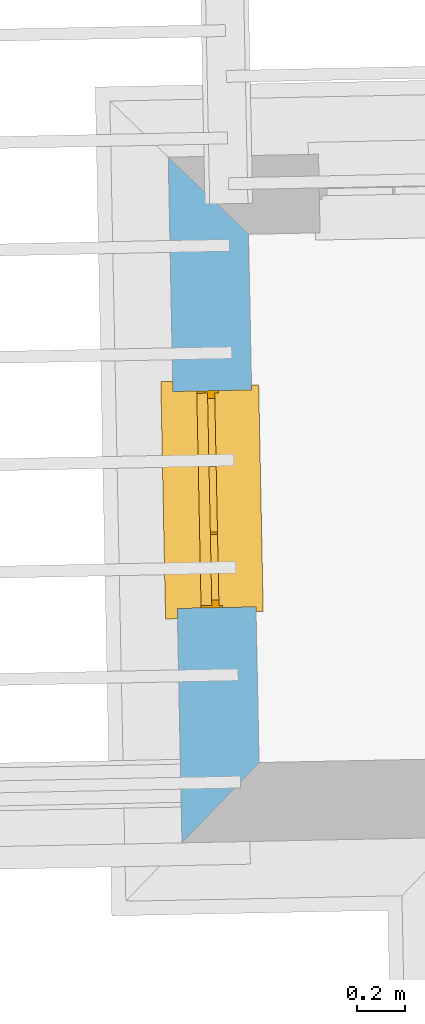
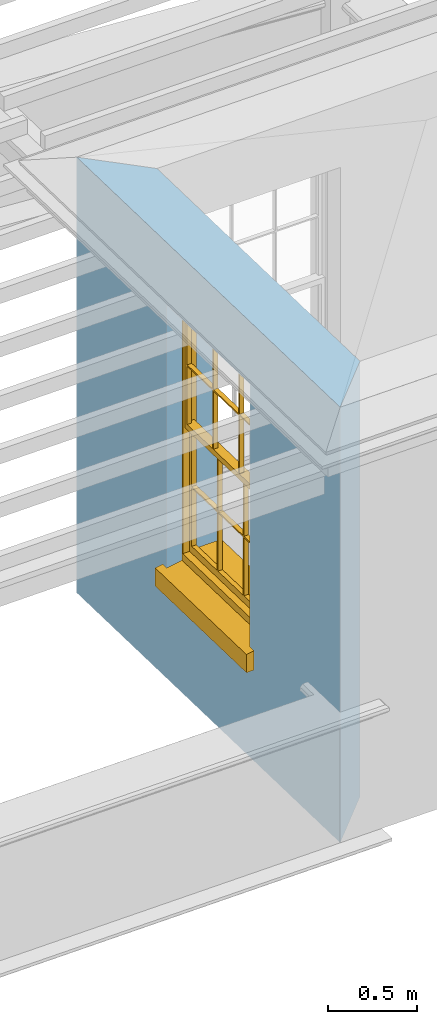
# One storey, part 6 of 11: 1 window, 1 opening, plus 1 element that does not belong to this part.
"""IFC2X3 building model written with IfcOpenShell, lengths in metres."""

from ifc_helpers import new_model, si_unit, frame, origin, place, context, subcontext, project, spatial, polyline, outline, extrude, faceted_brep, material, layer, layer_set, layer_usage, element, fill, save


model = new_model("IFC2X3")

# Units and contexts
model_context = context("Model", 3, world=origin())
body_context = subcontext(model_context, "Body", "Model", "MODEL_VIEW")
ifc_project = project(units=[si_unit("PLANEANGLEUNIT", "RADIAN"), si_unit("MASSUNIT", "GRAM", prefix="KILO"), si_unit("FORCEUNIT", "NEWTON", prefix="KILO"), si_unit("LENGTHUNIT", "METRE")], contexts=[model_context])

# Site, building, storey
site_placement = place(None, origin())
site = spatial("IfcSite", under=ifc_project, at=site_placement, CompositionType="ELEMENT")
building_placement = place(None, origin())
building = spatial("IfcBuilding", under=site, at=building_placement, Name="Building plot-11", CompositionType="ELEMENT")
storey_placement = place(None, frame((0.0, 0.0, 5.3)))
storey = spatial("IfcBuildingStorey", under=building, at=storey_placement, Name="Floor 1", CompositionType="ELEMENT", Elevation=5.3)

# Wall, opening, window
ifc_material = material(Name="Masonry")
ifc_layer = layer(ifc_material, 0.33, ventilated=False)
ifc_layer_set = layer_set([ifc_layer], Name="My Wall")
ifc_layer_usage = layer_usage(ifc_layer_set, "AXIS2", "NEGATIVE", 0.08)
wall_placement = place(storey_placement, origin())
wall = element("IfcWallStandardCase", 1, at=wall_placement, inside=storey, material=ifc_layer_usage, Name="exterior", context=body_context, shape_type="SweptSolid", body=[
    extrude(outline(polyline([(58.7998507375589, 22.5847820884662), (58.4633191417055, 22.9081185772706), (58.5207858909592, 20.0342901482081), (58.8441223797636, 20.3708217440617), (58.7998507375589, 22.5847820884662)])), origin(), (0.0, 0.0, 1.0), 3.0),
])
opening_placement = place(storey_placement, frame((0.0, 0.0, 0.75)))
opening = element("IfcOpeningElement", 2, at=opening_placement, cuts=wall, Name="Opening", ObjectType="Opening", context=body_context, shape_type="SweptSolid", body=[
    extrude(outline(polyline([(58.4829558895032, 21.926113421102), (58.5011491431615, 21.0162953043769), (58.8310831854904, 21.0228928579013), (58.8128899318321, 21.9327109746264), (58.4829558895032, 21.926113421102)])), origin(), (0.0, 0.0, 1.0), 1.82),
])
window_placement = place(storey_placement, frame((58.7329059215706, 21.9311115677114, 0.75), z_axis=(0.0, 0.0, 1.0), x_axis=(0.0181932536582607, -0.909818116725166, 0.0)))
window = element("IfcWindow", 3, at=window_placement, inside=storey, Name="circulation outside window", OverallHeight=1.82, OverallWidth=0.91, context=body_context, shape_type="Brep", held_by="IfcProductRepresentation", body=[
    faceted_brep([(0.033125, -0.105, 0.975209), (0.01, -0.105, 0.975209), (0.033125, -0.105, 1.376042), (0.876875, -0.105, 0.975209), (0.876875, -0.105, 1.376042), (0.9, -0.105, 0.975209), (0.876875, -0.105, 1.386042), (0.876875, -0.105, 1.786875), (0.9, -0.105, 1.81), (0.033125, -0.105, 1.786875), (0.033125, -0.105, 1.386042), (0.01, -0.105, 1.81), (0.876875, -0.135, 1.376042), (0.876875, -0.135, 0.975209), (0.9, -0.135, 0.937083), (0.033125, -0.135, 1.786875), (0.01, -0.135, 1.81), (0.033125, -0.135, 1.386042), (0.01, -0.135, 0.937083), (0.033125, -0.135, 0.975209), (0.033125, -0.135, 1.376042), (0.876875, -0.135, 1.786875), (0.876875, -0.135, 1.386042), (0.9, -0.135, 1.81), (0.033125, -0.105, 0.937083), (0.01, -0.105, 0.937083), (0.033125, -0.105, 0.53625), (0.876875, -0.105, 0.937083), (0.876875, -0.105, 0.53625), (0.9, -0.105, 0.937083), (0.876875, -0.105, 0.52625), (0.876875, -0.105, 0.125417), (0.9, -0.105, 0.077167), (0.033125, -0.105, 0.125417), (0.033125, -0.105, 0.52625), (0.01, -0.105, 0.077167), (-0.0425, -0.25, 0.01), (-0.0425, -0.3, 0.001667), (0.0, -0.25, 0.01), (0.9525, -0.25, 0.01), (0.91, -0.25, 0.01), (0.9525, -0.3, 0.001667), (-0.02, 0.08, 0.077167), (0.0, 0.08, 0.077167), (-0.02, 0.11, 0.077167), (0.0, -0.06, 0.077167), (0.01, -0.06, 0.077167), (0.91, -0.06, 0.077167), (0.91, 0.08, 0.077167), (0.9, -0.06, 0.077167), (0.93, 0.08, 0.077167), (0.93, 0.11, 0.077167), (0.01, -0.075, 0.975209), (0.9, -0.075, 0.975209), (0.876875, -0.075, 0.125417), (0.876875, -0.075, 0.52625), (0.9, -0.075, 0.077167), (0.876875, -0.075, 0.53625), (0.876875, -0.075, 0.937083), (0.033125, -0.075, 0.125417), (0.01, -0.075, 0.077167), (0.033125, -0.075, 0.52625), (0.033125, -0.075, 0.937083), (0.033125, -0.075, 0.53625), (-0.02, 0.08, 0.052167), (-0.02, 0.11, 0.052167), (0.93, 0.11, 0.052167), (0.93, 0.08, 0.052167), (0.91, 0.08, 0.052167), (0.0, 0.08, 0.052167), (0.91, -0.15, 0.026667), (0.0, -0.15, 0.026667), (-0.0425, -0.3, -0.123333), (0.9525, -0.3, -0.123333), (-0.0425, -0.25, -0.123333), (0.9525, -0.25, -0.123333), (0.01, -0.06, 1.81), (0.9, -0.06, 1.81), (0.0, -0.06, 1.82), (0.91, -0.06, 1.82), (0.01, -0.15, 0.077167), (0.9, -0.15, 0.077167), (0.592292, -0.105, 0.125417), (0.592292, -0.075, 0.125417), (0.317708, -0.075, 0.125417), (0.317708, -0.105, 0.125417), (0.592292, -0.105, 0.53625), (0.317708, -0.105, 0.53625), (0.317708, -0.105, 0.52625), (0.592292, -0.105, 0.52625), (0.592292, -0.075, 0.53625), (0.317708, -0.075, 0.53625), (0.592292, -0.135, 1.386042), (0.592292, -0.105, 1.386042), (0.317708, -0.105, 1.386042), (0.317708, -0.135, 1.386042), (0.317708, -0.135, 1.376042), (0.592292, -0.135, 1.376042), (0.317708, -0.105, 1.376042), (0.592292, -0.105, 1.376042), (0.602292, -0.135, 1.376042), (0.592292, -0.135, 0.975209), (0.602292, -0.135, 0.975209), (0.602292, -0.105, 0.975209), (0.592292, -0.105, 0.975209), (0.602292, -0.105, 1.376042), (0.602292, -0.075, 0.53625), (0.602292, -0.105, 0.53625), (0.317708, -0.075, 0.52625), (0.307708, -0.075, 0.125417), (0.307708, -0.075, 0.52625), (0.602292, -0.075, 0.52625), (0.602292, -0.075, 0.125417), (0.592292, -0.075, 0.52625), (0.307708, -0.075, 0.53625), (0.317708, -0.075, 0.937083), (0.307708, -0.075, 0.937083), (0.602292, -0.075, 0.937083), (0.592292, -0.075, 0.937083), (0.307708, -0.105, 0.52625), (0.307708, -0.105, 0.125417), (0.307708, -0.105, 0.53625), (0.307708, -0.105, 0.937083), (0.592292, -0.105, 0.937083), (0.317708, -0.105, 0.937083), (0.602292, -0.105, 0.937083), (0.602292, -0.105, 0.52625), (0.602292, -0.105, 0.125417), (0.307708, -0.135, 1.386042), (0.307708, -0.135, 1.376042), (0.307708, -0.135, 0.975209), (0.317708, -0.135, 0.975209), (0.317708, -0.135, 1.786875), (0.307708, -0.135, 1.786875), (0.602292, -0.135, 1.786875), (0.592292, -0.135, 1.786875), (0.602292, -0.135, 1.386042), (0.602292, -0.105, 1.386042), (0.307708, -0.105, 1.386042), (0.307708, -0.105, 1.786875), (0.317708, -0.105, 1.786875), (0.592292, -0.105, 1.786875), (0.602292, -0.105, 1.786875), (0.307708, -0.105, 1.376042), (0.317708, -0.105, 0.975209), (0.307708, -0.105, 0.975209), (0.91, -0.15, 1.82), (0.9, -0.15, 1.81), (0.01, -0.15, 1.81), (0.0, -0.15, 1.82), (0.91, -0.25, 0.0), (0.0, -0.25, 0.0), (0.91, 0.08, 0.0), (0.0, 0.08, 0.0)], [[[0, 1, 2]], [[3, 4, 5]], [[6, 7, 8]], [[9, 10, 11]], [[12, 13, 14]], [[15, 16, 17]], [[18, 19, 20]], [[21, 22, 23]], [[24, 25, 26]], [[27, 28, 29]], [[30, 31, 32]], [[33, 34, 35]], [[14, 27, 29]], [[25, 24, 18]], [[36, 37, 38]], [[39, 40, 41]], [[42, 43, 44]], [[45, 46, 43]], [[47, 48, 49]], [[50, 51, 48]], [[1, 0, 52]], [[5, 53, 3]], [[54, 55, 56]], [[57, 58, 53]], [[59, 60, 61]], [[62, 63, 52]], [[48, 43, 46, 49]], [[51, 44, 43, 48]], [[64, 42, 44, 65]], [[65, 44, 51, 66]], [[66, 51, 50, 67]], [[65, 66, 68, 69]], [[60, 56, 49, 46]], [[70, 71, 38, 40]], [[37, 41, 40, 38]], [[37, 72, 73, 41]], [[74, 75, 73, 72]], [[8, 11, 76, 77]], [[76, 78, 79, 77]], [[32, 35, 80, 81]], [[81, 80, 71, 70]], [[82, 83, 84, 85]], [[86, 87, 88, 89]], [[86, 90, 91, 87]], [[92, 93, 94, 95]], [[92, 95, 96, 97]], [[96, 98, 99, 97]], [[100, 97, 101, 102]], [[103, 104, 99, 105]], [[97, 99, 104, 101]], [[102, 103, 105, 100]], [[28, 57, 106, 107]], [[108, 84, 109, 110]], [[111, 112, 83, 113]], [[114, 110, 61, 63]], [[90, 113, 108, 91]], [[115, 91, 114, 116]], [[117, 106, 90, 118]], [[111, 106, 57, 55]], [[119, 110, 109, 120]], [[34, 61, 110, 119]], [[89, 113, 83, 82]], [[88, 108, 113, 89]], [[85, 84, 108, 88]], [[121, 114, 63, 26]], [[122, 116, 114, 121]], [[123, 118, 90, 86]], [[87, 91, 115, 124]], [[107, 106, 117, 125]], [[126, 111, 55, 30]], [[127, 112, 111, 126]], [[126, 30, 28, 107]], [[88, 119, 120, 85]], [[126, 89, 82, 127]], [[125, 123, 86, 107]], [[121, 26, 34, 119]], [[124, 122, 121, 87]], [[128, 17, 20, 129]], [[96, 129, 130, 131]], [[132, 133, 128, 95]], [[134, 135, 92, 136]], [[100, 12, 22, 136]], [[137, 6, 4, 105]], [[94, 138, 139, 140]], [[137, 93, 141, 142]], [[99, 98, 94, 93]], [[143, 2, 10, 138]], [[144, 145, 143, 98]], [[129, 143, 145, 130]], [[20, 2, 143, 129]], [[131, 144, 98, 96]], [[128, 138, 10, 17]], [[133, 139, 138, 128]], [[135, 141, 93, 92]], [[95, 94, 140, 132]], [[22, 6, 137, 136]], [[136, 137, 142, 134]], [[100, 105, 4, 12]], [[107, 86, 89, 126]], [[106, 111, 113, 90]], [[91, 108, 110, 114]], [[87, 121, 119, 88]], [[97, 100, 136, 92]], [[129, 96, 95, 128]], [[98, 143, 138, 94]], [[105, 99, 93, 137]], [[131, 101, 104, 144]], [[124, 115, 118, 123]], [[132, 140, 141, 135]], [[120, 109, 59, 33]], [[15, 9, 139, 133]], [[134, 142, 7, 21]], [[31, 54, 112, 127]], [[36, 74, 72, 37]], [[39, 41, 73, 75]], [[18, 14, 101, 131]], [[23, 16, 132, 135]], [[83, 56, 60, 84]], [[52, 53, 118, 115]], [[53, 52, 144, 104]], [[11, 8, 141, 140]], [[14, 18, 124, 123]], [[2, 1, 11, 10]], [[8, 5, 4, 6]], [[57, 53, 56, 55]], [[60, 52, 63, 61]], [[26, 25, 35, 34]], [[32, 29, 28, 30]], [[14, 23, 22, 12]], [[18, 20, 17, 16]], [[19, 0, 2, 20]], [[17, 10, 9, 15]], [[12, 4, 3, 13]], [[21, 7, 6, 22]], [[27, 58, 57, 28]], [[30, 55, 54, 31]], [[33, 59, 61, 34]], [[26, 63, 62, 24]], [[5, 8, 77, 53]], [[76, 11, 1, 52]], [[46, 45, 78, 76]], [[49, 77, 79, 47]], [[70, 146, 147, 81]], [[71, 80, 148, 149]], [[19, 130, 145, 0]], [[102, 13, 3, 103]], [[116, 122, 24, 62]], [[29, 32, 81, 14]], [[80, 35, 25, 18]], [[60, 46, 76, 52]], [[77, 49, 56, 53]], [[23, 14, 81, 147]], [[16, 148, 80, 18]], [[35, 85, 120]], [[120, 33, 35]], [[127, 82, 32]], [[32, 31, 127]], [[32, 82, 85, 35]], [[102, 101, 14]], [[14, 13, 102]], [[18, 131, 130]], [[130, 19, 18]], [[134, 21, 23]], [[23, 135, 134]], [[16, 15, 133]], [[133, 132, 16]], [[11, 140, 139]], [[139, 9, 11]], [[142, 141, 8]], [[8, 7, 142]], [[23, 147, 148, 16]], [[146, 149, 148, 147]], [[52, 115, 116]], [[116, 62, 52]], [[118, 53, 117]], [[58, 117, 53]], [[27, 125, 117, 58]], [[56, 83, 112]], [[112, 54, 56]], [[109, 84, 60]], [[60, 59, 109]], [[125, 27, 14]], [[14, 123, 125]], [[122, 124, 18]], [[18, 24, 122]], [[145, 144, 52]], [[52, 0, 145]], [[103, 3, 53]], [[53, 104, 103]], [[79, 78, 149, 146]], [[78, 45, 71, 149]], [[146, 70, 47, 79]], [[150, 75, 74, 151]], [[68, 66, 67]], [[48, 68, 67, 50]], [[69, 64, 65]], [[42, 64, 69, 43]], [[69, 68, 152, 153]], [[70, 68, 48, 47]], [[150, 152, 68, 70]], [[43, 69, 71, 45]], [[69, 153, 151, 71]], [[152, 150, 151, 153]], [[38, 151, 74, 36]], [[71, 151, 38]], [[39, 75, 150, 40]], [[40, 150, 70]]]),
])
fill(opening, window)

save(model, "model.ifc")
